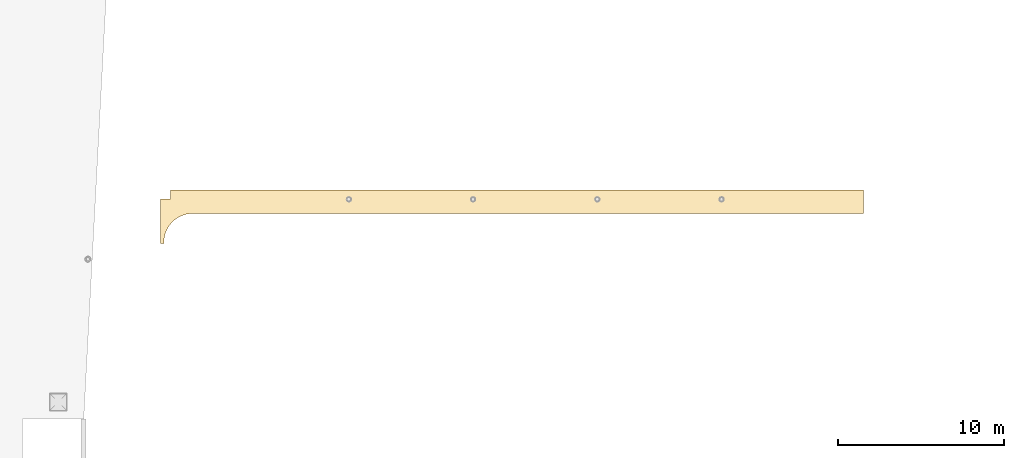
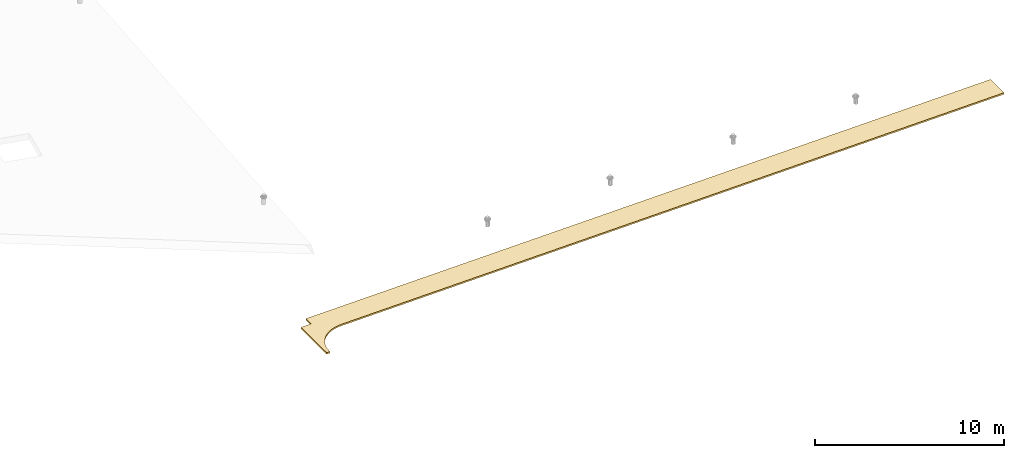
# One storey, part 12 of 18: 1 covering.
"""IFC2X3 building model written with IfcOpenShell, lengths in centimetres."""

from ifc_helpers import new_model, entity, si_unit, converted_unit, derived_unit, direction, frame, origin, place, context, subcontext, project, spatial, faceted_brep, material, layer, layer_set, layer_usage, element, save


model = new_model("IFC2X3")

# Units and contexts
model_context = context("Model", 3, precision=0.001, world=origin(), true_north=direction((6.12303176911189e-17, 1.0)))
body_context = subcontext(model_context, "Body", "Model", "MODEL_VIEW")
ifc_project = project(units=[si_unit("LENGTHUNIT", "METRE", prefix="CENTI"), si_unit("AREAUNIT", "SQUARE_METRE"), si_unit("VOLUMEUNIT", "CUBIC_METRE"), converted_unit("PLANEANGLEUNIT", "DEGREE", entity("IfcRatioMeasure", 0.0174532925199433), si_unit("PLANEANGLEUNIT", "RADIAN"), dimensions=[0, 0, 0, 0, 0, 0, 0]), si_unit("MASSUNIT", "GRAM", prefix="KILO"), derived_unit("MASSDENSITYUNIT", [(si_unit("MASSUNIT", "GRAM", prefix="KILO"), 1), (si_unit("LENGTHUNIT", "METRE"), -3)]), si_unit("TIMEUNIT", "SECOND"), si_unit("FREQUENCYUNIT", "HERTZ"), si_unit("THERMODYNAMICTEMPERATUREUNIT", "DEGREE_CELSIUS"), derived_unit("THERMALTRANSMITTANCEUNIT", [(si_unit("MASSUNIT", "GRAM", prefix="KILO"), 1), (si_unit("THERMODYNAMICTEMPERATUREUNIT", "KELVIN"), -1), (si_unit("TIMEUNIT", "SECOND"), -3)]), derived_unit("VOLUMETRICFLOWRATEUNIT", [(si_unit("LENGTHUNIT", "METRE"), 3), (si_unit("TIMEUNIT", "SECOND"), -1)]), si_unit("ELECTRICCURRENTUNIT", "AMPERE"), si_unit("ELECTRICVOLTAGEUNIT", "VOLT"), si_unit("POWERUNIT", "WATT"), si_unit("FORCEUNIT", "NEWTON", prefix="KILO"), si_unit("ILLUMINANCEUNIT", "LUX"), si_unit("LUMINOUSFLUXUNIT", "LUMEN"), si_unit("LUMINOUSINTENSITYUNIT", "CANDELA"), derived_unit("USERDEFINED", [(si_unit("MASSUNIT", "GRAM", prefix="KILO"), -1), (si_unit("LENGTHUNIT", "METRE"), -2), (si_unit("TIMEUNIT", "SECOND"), 3), (si_unit("LUMINOUSFLUXUNIT", "LUMEN"), 1)]), derived_unit("LINEARVELOCITYUNIT", [(si_unit("LENGTHUNIT", "METRE"), 1), (si_unit("TIMEUNIT", "SECOND"), -1)]), si_unit("PRESSUREUNIT", "PASCAL"), derived_unit("USERDEFINED", [(si_unit("LENGTHUNIT", "METRE"), -2), (si_unit("MASSUNIT", "GRAM", prefix="KILO"), 1), (si_unit("TIMEUNIT", "SECOND"), -2)])], contexts=[model_context])

# Site, building, storey
site_placement = place(None, origin())
site = spatial("IfcSite", under=ifc_project, at=site_placement, CompositionType="ELEMENT")
building_placement = place(site_placement, origin())
building = spatial("IfcBuilding", under=site, at=building_placement, CompositionType="ELEMENT")
storey_placement = place(building_placement, frame((0.0, 0.0, 1422.0)))
storey = spatial("IfcBuildingStorey", under=building, at=storey_placement, CompositionType="ELEMENT", Elevation=1422.0)

# Covering
ifc_material = material(Name="Isolant")
ifc_layer = layer(ifc_material, 10.0)
ifc_layer_set = layer_set([ifc_layer])
ifc_layer_usage = layer_usage(ifc_layer_set, "AXIS3", "NEGATIVE", 0.0)
covering_placement = place(storey_placement, frame((10387.4080481627, 3124.83435536901, -1407.5855625612)))
element("IfcCovering", 1, at=covering_placement, inside=storey, material=ifc_layer_usage, PredefinedType="CEILING", context=body_context, shape_type="Brep", body=[
    faceted_brep([(4246.6661117899, 325.65952735175, 92.3872041916989), (583.0, 325.65952735175, 21.3120816260248), (60.0000001572221, 325.659527223592, 11.1658816260248), (60.0000001572221, 270.659527223592, 11.1658816260248), (0.0, 270.659527223592, 10.0018816229748), (0.0, 0.159527223592023, 10.0018816229748), (20.1829527763514, 0.159527223592023, 10.3934309068359), (20.1354703253518, 15.0440215158013, 10.3925097472866), (21.3530102695363, 29.8787113137813, 10.4161300222038), (23.8267645601853, 44.5562780272205, 10.4641208554424), (27.5388373176512, 58.9705397412742, 10.5361350669372), (32.462374295512, 73.0172193683468, 10.6316516843076), (38.5617571522303, 86.5946990197828, 10.749979711728), (45.7928611249087, 99.6047551401177, 10.8902631287981), (54.1033742410516, 111.953269085706, 11.0514870832511), (63.4331757590354, 123.550908007184, 11.2324852327002), (73.7147710995735, 134.313771110067, 11.4319481823066), (84.8737801217187, 144.163996618231, 11.6484329573361), (96.8294752110817, 153.03032504933, 11.8803734420698), (109.495365287594, 160.848614727237, 12.1260917095542), (122.779821507877, 167.562305802148, 12.3838101602276), (136.586740135757, 173.122829421477, 12.6516643816084), (150.816237785472, 177.48995909149, 12.9277166360129), (165.365374008024, 180.632101687809, 13.2099698787304), (180.128895993215, 182.52652600954, 13.4963822052431), (195.0, 183.159527223592, 13.7848816229751), (4246.6661117899, 183.159527223591, 92.3872041916989), (0.0, 270.659527223592, 0.0), (60.0000001572221, 270.659527223592, 1.16400000305022), (60.0000001572221, 325.659527223592, 1.16400000305022), (583.0, 325.65952735175, 11.31020000305), (4246.6661117899, 325.65952735175, 82.3853225687241), (4246.6661117899, 183.159527223591, 82.3853225687241), (195.0, 183.159527223592, 3.78300000000031), (180.128895993215, 182.52652600954, 3.49450058226847), (165.365374008024, 180.632101687809, 3.20808825575578), (150.816237785472, 177.48995909149, 2.92583501303826), (136.586740135757, 173.122829421477, 2.6497827586338), (122.779821507877, 167.562305802148, 2.38192853725283), (109.495365287594, 160.848614727237, 2.1242100865794), (96.8294752110817, 153.03032504933, 1.87849181909495), (84.8737801217187, 144.163996618231, 1.64655133436133), (73.7147710995735, 134.313771110067, 1.43006655933175), (63.4331757590354, 123.550908007184, 1.23060360972536), (54.1033742410516, 111.953269085706, 1.0496054602765), (45.7928611249087, 99.6047551401177, 0.888381505823268), (38.5617571522303, 86.5946990197828, 0.748098088753398), (32.462374295512, 73.0172193683468, 0.629770061333017), (27.5388373176512, 58.9705397412742, 0.534253443962603), (23.8267645601853, 44.5562780272205, 0.462239232467562), (21.3530102695363, 29.8787113137813, 0.414248399229027), (20.1354703253518, 15.0440215158013, 0.390628124311813), (20.1829527763514, 0.159527223592023, 0.391549283861315), (0.0, 0.159527223592023, 0.0)], [[[0, 1, 2, 3, 4, 5, 6, 7, 8, 9, 10, 11, 12, 13, 14, 15, 16, 17, 18, 19, 20, 21, 22, 23, 24, 25, 26]], [[27, 28, 29, 30, 31, 32, 33, 34, 35, 36, 37, 38, 39, 40, 41, 42, 43, 44, 45, 46, 47, 48, 49, 50, 51, 52, 53]], [[0, 31, 30, 29, 2, 1]], [[5, 4, 27, 53]], [[32, 26, 25, 33]], [[0, 26, 32, 31]], [[6, 5, 53, 52]], [[3, 2, 29, 28]], [[4, 3, 28, 27]], [[48, 10, 9, 49]], [[50, 8, 7, 51]], [[52, 51, 7, 6]], [[8, 50, 49, 9]], [[43, 15, 14, 44]], [[45, 13, 12, 46]], [[46, 12, 11, 47]], [[13, 45, 44, 14]], [[47, 11, 10, 48]], [[43, 42, 16, 15]], [[38, 20, 19, 39]], [[40, 18, 17, 41]], [[41, 17, 16, 42]], [[18, 40, 39, 19]], [[33, 25, 24, 34]], [[35, 23, 22, 36]], [[36, 22, 21, 37]], [[23, 35, 34, 24]], [[37, 21, 20, 38]]]),
])

save(model, "model.ifc")
